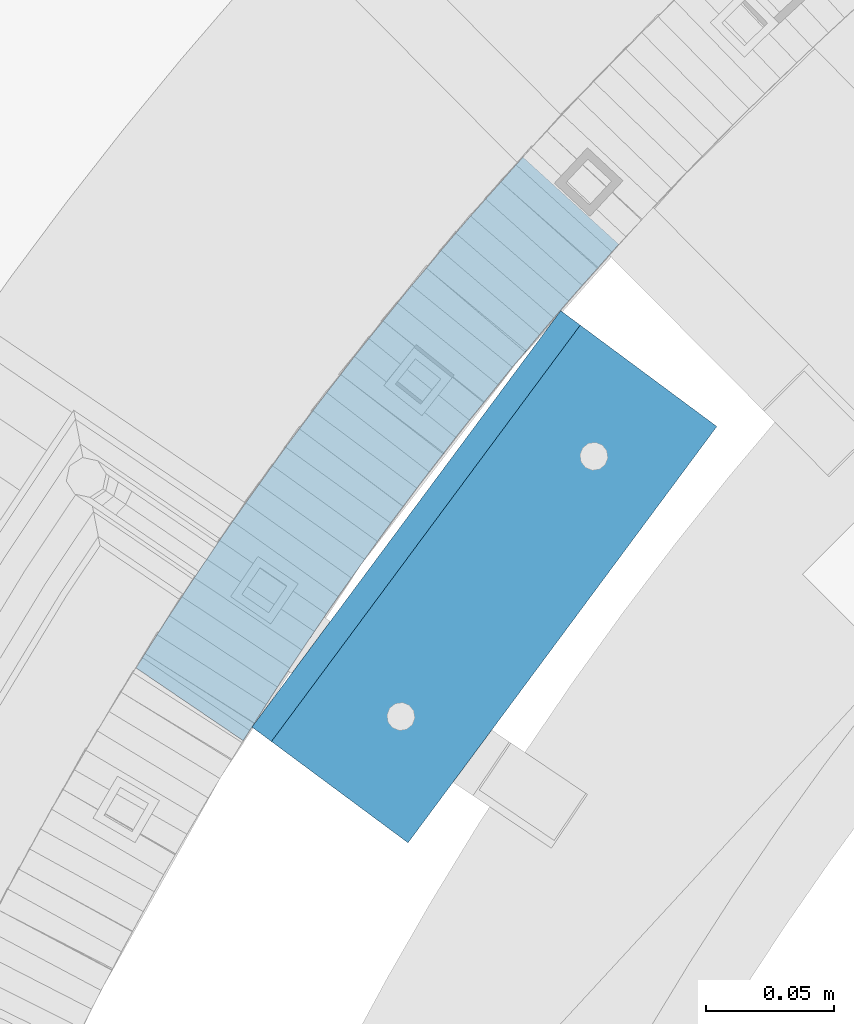
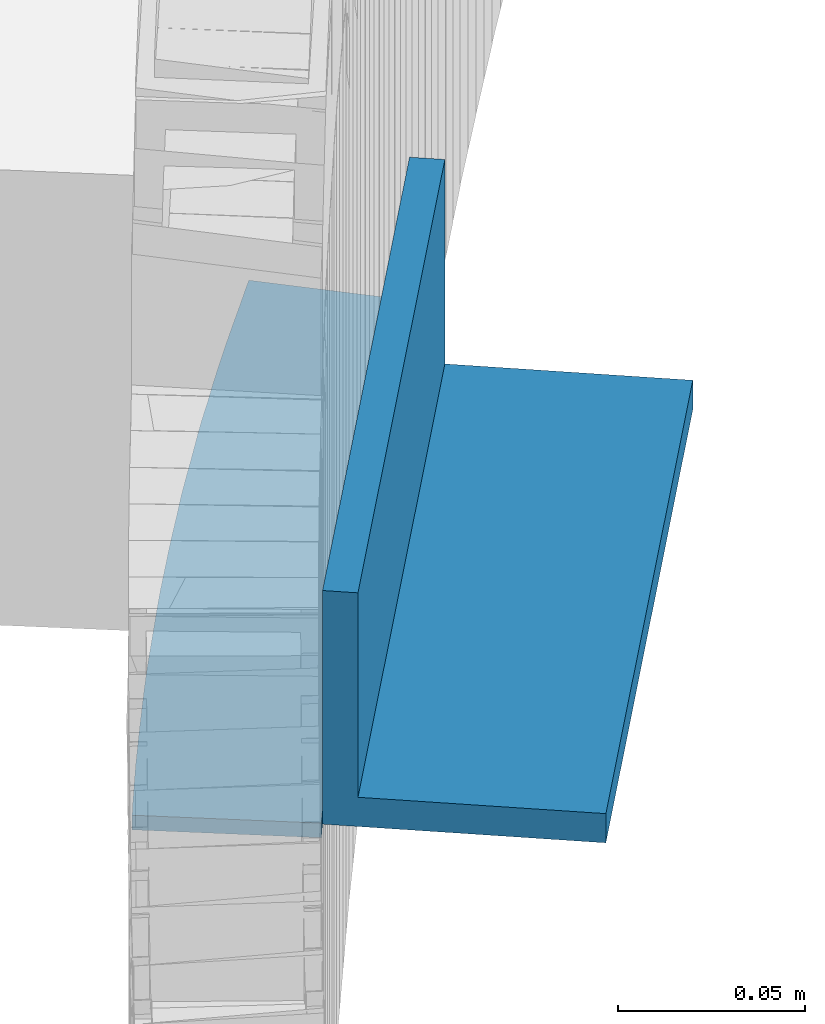
# One storey, part 483 of 975: 2 beams.
"""IFC2X3 building model written with IfcOpenShell, lengths in millimetres."""

from ifc_helpers import new_model, si_unit, frame, origin_with_axes, place, context, subcontext, project, spatial, faceted_brep, material, type_object, element, save


model = new_model("IFC2X3")

# Units and contexts
model_context = context("Model", 3, precision=1e-05, world=origin_with_axes())
body_context = subcontext(model_context, "Body", "Model", "MODEL_VIEW")
ifc_project = project(units=[si_unit("LENGTHUNIT", "METRE", prefix="MILLI"), si_unit("AREAUNIT", "SQUARE_METRE"), si_unit("VOLUMEUNIT", "CUBIC_METRE"), si_unit("MASSUNIT", "GRAM", prefix="KILO"), si_unit("TIMEUNIT", "SECOND"), si_unit("PLANEANGLEUNIT", "RADIAN"), si_unit("SOLIDANGLEUNIT", "STERADIAN"), si_unit("THERMODYNAMICTEMPERATUREUNIT", "DEGREE_CELSIUS"), si_unit("LUMINOUSINTENSITYUNIT", "LUMEN")], contexts=[model_context])

# Site, building, storey
site_placement = place(None, origin_with_axes())
site = spatial("IfcSite", under=ifc_project, at=site_placement, CompositionType="ELEMENT")
building_placement = place(site_placement, origin_with_axes())
building = spatial("IfcBuilding", under=site, at=building_placement, Name="Undefined", CompositionType="ELEMENT")
storey_placement = place(building_placement, origin_with_axes())
storey = spatial("IfcBuildingStorey", under=building, at=storey_placement, Name="Undefined", CompositionType="ELEMENT", Elevation=0.0)

# Beams
ifc_material = material(Name="STEEL/A36")
beam_type_1 = type_object("IfcBeamType", PredefinedType="NOTDEFINED")
beam_1_placement = place(storey_placement, frame((33571.9246376647, 4131.67933649359, 2.38162654007597), z_axis=(0.827279193066025, -0.56179100804483, 0.0), x_axis=(0.561791008044794, 0.827279193065973, -3.56000000027958e-07)))
element("IfcBeam", 1, at=beam_1_placement, inside=storey, type_object=beam_type_1, material=ifc_material, Name="PLATE", context=body_context, shape_type="Brep", body=[
    faceted_brep([(246.957811566823, 2.38099999999997, -38.2080252488813), (237.98179833519, 2.38099999999997, -39.3399382914831), (229.186958425889, 2.38099999999997, -40.5246481824506), (220.210945194256, 2.38099999999997, -41.656561463471), (211.409786245324, 2.38099999999997, -42.6907808317774), (202.525897959182, 2.38099999999998, -43.6688216267794), (193.724346105224, 2.38099999999998, -44.4959677834013), (184.731578729214, 2.38099999999998, -45.4859948294325), (175.877323020839, 2.38099999999998, -46.2424002840526), (167.100353082024, 2.38099999999998, -46.9289576813389), (158.086078452168, 2.38099999999998, -47.6990330968147), (149.275813835327, 2.38099999999998, -48.3924502720547), (140.241740938745, 2.38099999999998, -48.8778500885492), (131.404933664227, 2.38099999999998, -49.4323617374466), (122.557750416436, 2.38099999999998, -49.9094026064849), (113.519679720564, 2.38099999999999, -50.3136247113216), (104.69518629463, 2.38099999999999, -50.7312440420246), (95.7362629437521, 2.38099999999999, -50.9911027468988), (86.691432612879, 2.38099999999999, -51.1937715067179), (77.8153492304082, 2.38099999999999, -51.3926580013649), (68.83040964662, 2.38099999999999, -51.5949128690772), (59.8997760990387, 2.38099999999999, -51.657467803183), (50.8527027356758, 2.38099999999999, -51.636339718425), (42.0607868441184, 2.38099999999999, -51.5889321950417), (33.186153059447, 2.38099999999999, -51.4853475288619), (24.3115040159864, 2.381, -51.3817619090041), (15.6908680395718, 2.381, -51.1478834074733), (6.7905842377113, 2.381, -50.8741117437421), (4.76198926935103, 2.381, -50.8188471846915), (2.5465851649642e-11, 2.381, -50.5847208915948), (0.0, 2.381, 0.14387817388706), (4.76199981924583, 2.381, 3.05183493765071e-06), (8.20708486792864, 2.381, -0.0941589354551979), (16.7372820115161, 2.381, -0.356076049676631), (25.3247835374314, 2.381, -0.590519714198308), (33.7790510392952, 2.38099999999999, -0.688809203908022), (42.3347036577361, 2.38099999999999, -0.789669799574767), (50.799501631398, 2.38099999999999, -0.789669799542025), (59.5055410601417, 2.38099999999999, -0.856411742868659), (67.6325361468444, 2.38099999999999, -0.808071899085917), (76.5929853656307, 2.38099999999999, -0.6072967525688), (85.5534345844135, 2.38099999999999, -0.406521606051683), (94.1821424701884, 2.38099999999999, -0.214260863827803), (102.712789748053, 2.38099999999999, 0.0326492314197822), (111.249952528848, 2.38099999999999, 0.435641479984042), (119.775648329658, 2.38099999999999, 0.816950989294128), (128.167234633402, 2.38099999999998, 1.26695556695995), (136.620741103161, 2.38099999999998, 1.79490203916066), (145.179807875658, 2.38099999999998, 2.26074523988063), (153.689146254594, 2.38099999999998, 2.91215057438603), (162.26531812963, 2.38099999999998, 3.64302368232529), (171.553312514436, 2.38099999999998, 4.37324066234214), (180.05654737775, 2.38099999999998, 5.09965820387515), (188.852491591646, 2.38099999999998, 6.0682632454118), (197.364561293831, 2.38099999999998, 6.86988372883934), (205.481092665927, 2.38099999999997, 7.76207275474371), (213.855192397405, 2.38099999999997, 8.74427337733141), (222.322355483378, 2.38099999999997, 9.81202240079801), (231.626051162126, 2.38099999999997, 11.0609008798383), (240.093198989307, 2.38099999999997, 12.1286422739104), (243.694563663139, 2.38099999999997, 12.6408657410793), (250.847160078523, 2.38099999999997, -37.6540553463965), (240.093200684587, -2.38100000000003, 12.1286422739286), (243.694565358419, -2.38100000000003, 12.6408657410902), (231.626052857409, -2.38100000000003, 11.0609008798529), (222.322357178655, -2.38100000000003, 9.8120224008162), (213.855194092688, -2.38100000000002, 8.7442733773496), (205.48109436121, -2.38100000000002, 7.76207275475826), (197.364562989111, -2.38100000000002, 6.86988372885389), (188.852493286926, -2.38100000000002, 6.06826324542271), (180.056549073026, -2.38100000000002, 5.09965820388607), (171.553314209712, -2.38100000000002, 4.37324066235306), (162.265319824906, -2.38100000000002, 3.64302368233621), (153.689147949874, -2.38100000000002, 2.91215057439695), (145.179809570938, -2.38100000000002, 2.26074523989155), (136.620742798445, -2.38100000000002, 1.79490203917885), (128.167236328685, -2.38100000000001, 1.26695556697814), (119.775650024938, -2.38100000000001, 0.816950989305042), (111.249954224131, -2.38100000000001, 0.435641480002232), (102.712791443329, -2.38100000000001, 0.0326492314306961), (94.1821441654647, -2.38100000000001, -0.214260863816889), (85.5534362796934, -2.38100000000001, -0.406521606029855), (76.592987060907, -2.38100000000001, -0.607296752554248), (67.6325378421243, -2.38100000000001, -0.808071899071365), (59.5055427554253, -2.38100000000001, -0.856411742857745), (50.799503326678, -2.38100000000001, -0.789669799531111), (42.3347053530124, -2.381, -0.789669799560215), (33.7790527345715, -2.381, -0.68880920389347), (25.3247852327113, -2.381, -0.590519714183756), (16.737283706796, -2.381, -0.356076049665717), (8.20708656321221, -2.381, -0.094158935444284), (4.76200151452213, -2.381, 3.05184585158713e-06), (1.09139364212751e-11, -2.381, 0.143878173901612), (3.27418092638254e-11, -2.381, -50.5847208915802), (4.76199096463097, -2.38099999838742, -50.8188471846806), (6.79058593299123, -2.38099999841567, -50.8741117437312), (15.690869734859, -2.38099999853957, -51.1478834074551), (24.3115057112664, -2.38099999865961, -51.3817619089932), (33.1861547547269, -2.38099999878338, -51.4853475288473), (42.0607885393983, -2.38099999890714, -51.5889321950272), (50.8527044309485, -2.38099999902982, -51.6363397184141), (59.8997777943187, -2.3809999991561, -51.6574678031684), (68.8304113419035, -2.38099999928086, -51.5949128690627), (77.8153509256845, -2.38099999940657, -51.392658001354), (86.6914343081626, -2.38099999953075, -51.193771506707), (95.736264639032, -2.38099999965729, -50.9911027468806), (104.69518798991, -2.3809999997827, -50.7312440420064), (113.519681415848, -2.38099999990645, -50.3136247113107), (122.557752111716, -2.38100000003316, -49.909402606474), (131.404935359511, -2.3810000001573, -49.4323617374284), (140.241742634029, -2.3810000002814, -48.877850088531), (149.275815530611, -2.38100000040816, -48.3924502720329), (158.086080147448, -2.38100000053207, -47.6990330968038), (167.100354777307, -2.38100000065892, -46.928957681328), (175.877324716115, -2.38100000078236, -46.242400284038), (184.731580424494, -2.38100000090696, -45.4859948294179), (193.7243478005, -2.38100000103381, -44.4959677833904), (202.525899654462, -2.38100000115777, -43.6688216267685), (211.409787940607, -2.38100000128308, -42.6907808317592), (220.210946889532, -2.38100000140731, -41.6565614634528), (229.186960121173, -2.3810000015341, -40.5246481824361), (237.981800030469, -2.38100000165844, -39.3399382914722), (246.957813262103, -2.38100000178524, -38.2080252488704), (250.8471617738, -2.38100000184026, -37.6540553463856)], [[[0, 1, 2, 3, 4, 5, 6, 7, 8, 9, 10, 11, 12, 13, 14, 15, 16, 17, 18, 19, 20, 21, 22, 23, 24, 25, 26, 27, 28, 29, 30, 31, 32, 33, 34, 35, 36, 37, 38, 39, 40, 41, 42, 43, 44, 45, 46, 47, 48, 49, 50, 51, 52, 53, 54, 55, 56, 57, 58, 59, 60, 61]], [[59, 62, 63, 60]], [[62, 64, 65, 66, 67, 68, 69, 70, 71, 72, 73, 74, 75, 76, 77, 78, 79, 80, 81, 82, 83, 84, 85, 86, 87, 88, 89, 90, 91, 92, 93, 94, 95, 96, 97, 98, 99, 100, 101, 102, 103, 104, 105, 106, 107, 108, 109, 110, 111, 112, 113, 114, 115, 116, 117, 118, 119, 120, 121, 122, 123, 63]], [[60, 63, 123, 61]], [[122, 0, 61, 123]], [[121, 1, 0, 122]], [[120, 2, 1, 121]], [[119, 3, 2, 120]], [[118, 4, 3, 119]], [[117, 5, 4, 118]], [[116, 6, 5, 117]], [[115, 7, 6, 116]], [[114, 8, 7, 115]], [[113, 9, 8, 114]], [[112, 10, 9, 113]], [[111, 11, 10, 112]], [[110, 12, 11, 111]], [[109, 13, 12, 110]], [[108, 14, 13, 109]], [[107, 15, 14, 108]], [[106, 16, 15, 107]], [[105, 17, 16, 106]], [[104, 18, 17, 105]], [[103, 19, 18, 104]], [[102, 20, 19, 103]], [[101, 21, 20, 102]], [[100, 22, 21, 101]], [[99, 23, 22, 100]], [[98, 24, 23, 99]], [[97, 25, 24, 98]], [[96, 26, 25, 97]], [[95, 27, 26, 96]], [[94, 28, 27, 95]], [[93, 29, 28, 94]], [[92, 30, 29, 93]], [[91, 31, 30, 92]], [[90, 32, 31, 91]], [[89, 33, 32, 90]], [[88, 34, 33, 89]], [[87, 35, 34, 88]], [[86, 36, 35, 87]], [[85, 37, 36, 86]], [[84, 38, 37, 85]], [[83, 39, 38, 84]], [[82, 40, 39, 83]], [[81, 41, 40, 82]], [[80, 42, 41, 81]], [[79, 43, 42, 80]], [[78, 44, 43, 79]], [[77, 45, 44, 78]], [[76, 46, 45, 77]], [[75, 47, 46, 76]], [[74, 48, 47, 75]], [[73, 49, 48, 74]], [[72, 50, 49, 73]], [[71, 51, 50, 72]], [[70, 52, 51, 71]], [[69, 53, 52, 70]], [[68, 54, 53, 69]], [[67, 55, 54, 68]], [[66, 56, 55, 67]], [[65, 57, 56, 66]], [[64, 58, 57, 65]], [[62, 59, 58, 64]]]),
])
beam_type_2 = type_object("IfcBeamType", Name="L3X3X3/8", PredefinedType="NOTDEFINED")
beam_2_placement = place(storey_placement, frame((33606.0571961603, 4114.25900145702, 38.1), z_axis=(0.0, 0.0, 1.0), x_axis=(0.59573344501429, 0.803182210019249, 0.0)))
element("IfcBeam", 2, at=beam_2_placement, inside=storey, type_object=beam_type_2, material=ifc_material, Name="ANGLE", ObjectType="L3X3X3/8", context=body_context, shape_type="Brep", body=[
    faceted_brep([(-6.18456397205591e-11, 38.0999999999876, -38.1000000000258), (1.45519152283669e-10, 38.1000000000295, 38.1000000000386), (203.199999998666, 38.0999999999513, 38.1), (203.199999998666, 38.0999999999513, -38.1), (4.72937244921923e-11, 28.5749999999316, 38.1), (203.199999998655, 28.5749999999716, 38.1), (4.72937244921923e-11, 28.5749999999316, -28.575), (203.199999998655, 28.5749999999716, -28.575), (-5.0931703299284e-11, -38.0999999999112, -28.575), (203.199999998556, -38.0999999998749, -28.575), (-1.41881173476577e-10, -38.1000000000258, -38.1000000000386), (203.199999998556, -38.0999999998749, -38.1)], [[[0, 1, 2, 3]], [[1, 4, 5, 2]], [[4, 6, 7, 5]], [[6, 8, 9, 7]], [[8, 10, 11, 9]], [[10, 0, 3, 11]], [[5, 7, 9, 11, 3, 2]], [[10, 8, 6, 4, 1, 0]]]),
])

save(model, "model.ifc")
